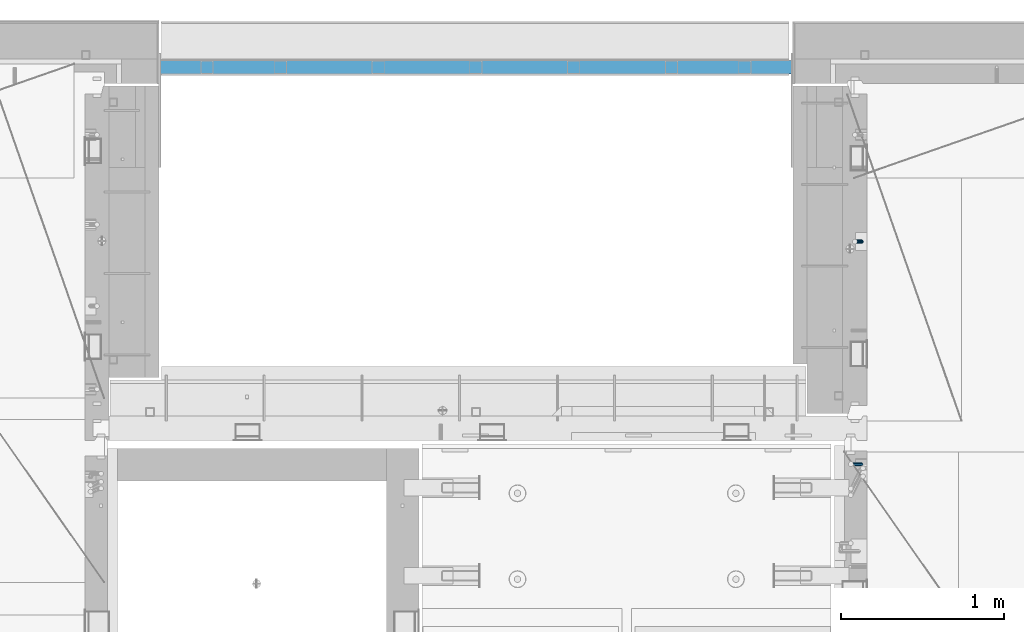
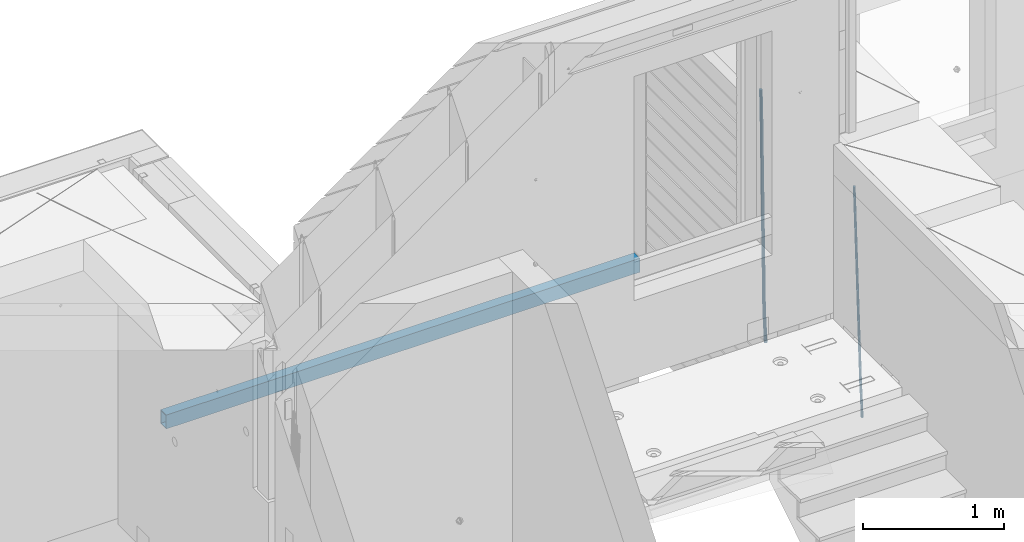
# One storey, part 125 of 350: 3 beams, 3 elements without a shape of their own.
"""IFC2X3 building model written with IfcOpenShell, lengths in millimetres."""

from ifc_helpers import new_model, si_unit, frame, origin_with_axes, place, context, subcontext, project, spatial, faceted_brep, material, type_object, element, aggregate, save


model = new_model("IFC2X3")

# Units and contexts
model_context = context("Model", 3, precision=1e-05, world=origin_with_axes())
body_context = subcontext(model_context, "Body", "Model", "MODEL_VIEW")
ifc_project = project(units=[si_unit("LENGTHUNIT", "METRE", prefix="MILLI"), si_unit("AREAUNIT", "SQUARE_METRE"), si_unit("VOLUMEUNIT", "CUBIC_METRE"), si_unit("MASSUNIT", "GRAM", prefix="KILO"), si_unit("TIMEUNIT", "SECOND"), si_unit("PLANEANGLEUNIT", "RADIAN"), si_unit("SOLIDANGLEUNIT", "STERADIAN"), si_unit("THERMODYNAMICTEMPERATUREUNIT", "DEGREE_CELSIUS"), si_unit("LUMINOUSINTENSITYUNIT", "LUMEN")], contexts=[model_context])

# Site, building, storey
site_placement = place(None, origin_with_axes())
site = spatial("IfcSite", under=ifc_project, at=site_placement, CompositionType="ELEMENT")
building_placement = place(site_placement, origin_with_axes())
building = spatial("IfcBuilding", under=site, at=building_placement, CompositionType="ELEMENT")
storey_placement = place(building_placement, origin_with_axes())
storey = spatial("IfcBuildingStorey", under=building, at=storey_placement, Name="2", CompositionType="ELEMENT", Elevation=0.0)

# Assembly, beam
assembly_1_placement = place(storey_placement, origin_with_axes())
assembly_1 = element("IfcElementAssembly", 1, at=assembly_1_placement, inside=storey, AssemblyPlace="NOTDEFINED", PredefinedType="REINFORCEMENT_UNIT")
ifc_material_1 = material()
beam_type_1 = type_object("IfcBeamType", Name="D20", PredefinedType="NOTDEFINED")
beam_1_placement = place(assembly_1_placement, frame((22375.0000022791, 20285.0000000039, 85390.0), z_axis=(-0.999642804636942, -0.000205726999925762, -0.0267249099902983), x_axis=(-0.0267249099948371, 4.30000201934385e-08, 0.999642825806181)))
beam_1 = element("IfcBeam", 2, at=beam_1_placement, type_object=beam_type_1, material=ifc_material_1, Name="JM20", ObjectType="D20", context=body_context, shape_type="Brep", body=[
    faceted_brep([(0.0, -10.0, 0.0), (-4.19531716033816e-08, -7.07106781186667, -7.07106781187031), (60.4266690400545, -7.0710677960451, -7.07106780570757), (60.4266690441291, -9.99999998418934, 6.15546014159918e-09), (0.0, 0.0, -10.0), (60.426669036824, 1.58106558956206e-08, -9.99999999384454), (4.196772351861e-08, 7.07106781186303, -7.07106781186667), (60.4266690363438, 7.07106782768096, -7.07106780570757), (0.0, 10.0, 0.0), (60.4266690388904, 10.0000000158179, 6.15182216279209e-09), (4.196772351861e-08, 7.07106781185939, 7.07106781185939), (60.4266690429649, 7.07106782768096, 7.07106781802577), (0.0, 0.0, 10.0), (60.4266690461809, 1.58179318532348e-08, 10.0000000061555), (-4.19531716033816e-08, -7.07106781187031, 7.07106781185939), (60.4266690466611, -7.07106779605238, 7.07106781802213), (61.0378400410118, -7.07106779588503, -7.07106780564936), (60.991799419251, -9.99999998403655, 6.21366780251265e-09), (61.0569027789461, 1.5985278878361e-08, -9.99999999378269), (61.0378209396877, 7.07106782784831, -7.07106780564936), (60.9917724058905, 10.0000000159635, 6.21366780251265e-09), (60.9457317841297, 7.07106782781193, 7.0710678180767), (60.9266690461809, 1.59488990902901e-08, 10.0000000062028), (60.9457508854539, -7.07106779591413, 7.0710678180767), (61.6489592143771, -7.07106614513759, -7.06310863441468), (61.5568818710308, -9.9999984576425, 0.00735959856683621), (61.6870830769039, 1.71821739058942e-06, -9.99179257185824), (61.6489210170112, 7.07106947854481, -7.06310888312146), (61.556827851804, 10.0000015422847, 0.00735924683976918), (61.4647505084577, 7.07106922979438, 7.07782747982128), (61.4266266459163, 1.36643211590126e-06, 10.0065114172685), (61.464788705809, -7.07106639389531, 7.07782772852806), (176.543135720174, -7.07075579406956, -5.56673531796696), (176.451058376813, -9.99968810657447, 1.50373291501455), (176.581259582701, 0.000312069292704109, -8.49541925541052), (176.543097522794, 7.07137982961285, -5.56673556667374), (176.451004357587, 10.00031189336, 1.50373256329476), (176.35892701424, 7.07137958085514, 8.57420079627263), (176.320803151699, 0.000311717507429421, 11.5028847337162), (176.358965211621, -7.07075604281999, 8.57420104497578), (177.098753836006, -7.07075429323595, -5.55949898843028), (176.98362511232, -9.99968666800123, 1.510669025065), (177.146421932586, 0.000313595905026887, -8.48805862247536), (177.098706077581, 7.07138133041735, -5.55949936166144), (176.983557571715, 10.0003133318824, 1.51066849724157), (176.868428848029, 7.07138095712435, 8.58083651073321), (176.820760751449, 0.000313067976094317, 11.5093961447819), (176.868476606425, -7.07075466652896, 8.58083688396073), (177.654312950661, -7.07075204110879, -5.54863964998367), (177.516135294456, -9.99968450931192, 1.52107783331303), (177.711524267797, 0.000315886711177882, -8.47701274570863), (177.654255632195, 7.07138358250813, -5.54864021007961), (177.516054233929, 10.0003154905207, 1.5210770412159), (177.377876577739, 7.0713830223176, 8.59079452451624), (177.320665260588, 0.000315094497636892, 11.5191676202448), (177.377933896176, -7.07075260129932, 8.59079508461218), (299.529725389817, -7.0702579820354, -3.16637947698109), (299.391547733612, -9.99919045023489, 3.90333800631561), (299.586936706939, 0.000809945799119305, -6.09475257270606), (299.529668071336, 7.07187764158152, -3.16638003707703), (299.391466673056, 10.000809549605, 3.90333721422212), (299.253289016866, 7.07187708140191, 10.9730546975188), (299.196077699729, 0.000809153574664379, 13.9014277932438), (299.253346335332, -7.07025854221502, 10.9730552576111), (300.053154890193, -7.07025586015152, -3.15614816594825), (299.971788958996, -9.99918809853989, 3.91467979818117), (300.086841216093, 0.000811972313385922, -6.08498109724314), (300.053121210876, 7.07187976355999, -3.15614826397359), (299.971753863239, 10.0008119014747, 3.91467990454839), (299.890387932071, 7.07187966407218, 10.9855078686815), (299.856701606172, 0.000811831610917579, 13.9143407999763), (299.890421611388, -7.07025595963933, 10.9855079667068), (300.576681224076, -7.07025548863749, -3.15433176753868), (300.552150063115, -9.99918768617863, 3.91669348816504), (300.586838206684, 0.000812327129096957, -6.08324633496159), (300.57667118829, 7.07188013509221, -3.15433178353487), (300.552135870385, 10.0008123138141, 3.91669346554409), (300.527604709423, 7.07188011626931, 10.9877187212514), (300.517447726816, 0.000812300502730068, 13.9166332886707), (300.52761474521, -7.07025550746039, 10.9877187372476), (1894.37298527778, -7.06912446613933, 2.37541694085667), (1894.34845411681, -9.99805666368775, 9.44644219656402), (1894.3831422604, 0.00194334961997811, -0.553497626566241), (1894.37297524199, 7.07301115758673, 2.37541692486411), (1894.34843992408, 10.0019433363086, 9.44644217394307), (1894.32390876314, 7.07301113876019, 16.5174674296468), (1894.31375178052, 0.00194332300088718, 19.4463819970697), (1894.32391879891, -7.06912448496587, 16.5174674456393), (1894.94254953373, -7.06912406195261, 2.37739306992808), (1894.864138918, -9.99805629773618, 9.44823138841821), (1895.01321576146, 0.00194379674576339, -0.551311557919689), (1895.03474228333, 7.0730116272025, 2.3777129556911), (1894.99451915483, 10.0019437947958, 9.44868377519742), (1894.9161085391, 7.07301155900859, 16.5195220936839), (1894.8454423114, 0.0019437003065832, 19.4482267215244), (1894.8239157895, -7.06912413014652, 16.5192022079245), (1895.51201837322, -7.07655005247943, 2.3849721376755), (1895.3797373289, -10.0047798068154, 9.45509349396525), (1895.6431837092, -0.00627111456196872, -0.542927306803904), (1895.69639846191, 7.06438349486052, 2.38651894584837), (1895.64049015092, 9.99352020044898, 9.45728101107306), (1895.50820910657, 7.06529044610943, 16.5274023673664), (1895.37704377061, -0.00498849180803518, 19.4553018118422), (1895.3238290179, -7.07564310123053, 16.5258555591899), (1917.3375872656, -7.36115994941429, 2.67544890068893), (1917.20530622125, -10.2893897037538, 9.74557025698232), (1917.46875260158, -0.29088101150046, -0.252450543786836), (1917.52196735426, 6.77977359792203, 2.67699570887271), (1917.46605904329, 9.70891030351049, 9.74775777409013), (1917.33377799895, 6.78068054917094, 16.8178791303835), (1917.20261266298, -0.289598388742888, 19.7457785748593), (1917.1493979103, -7.36025299817265, 16.816332322207), (1917.97302879854, -7.36944623740055, 2.68390599981285), (1917.86539582294, -10.2979974076115, 9.75435539755927), (1918.04706999661, -0.298422389005282, -0.244753710507212), (1918.04414708749, 6.77296426705288, 2.68394540532245), (1917.9659722717, 9.70239133243012, 9.75441112535555), (1917.85833929609, 6.77384016221913, 16.824860523102), (1917.78429809801, -0.297183686179778, 19.753520233422), (1917.78722100714, -7.36857034223431, 16.8248211175924), (1918.60852415283, -7.36757026622581, 2.69216814523315), (1918.52554118163, -10.29602885028, 9.76294518245413), (1918.62543662851, -0.296724680512853, -0.237251666560041), (1918.56637150982, 6.77450246020453, 2.69070014292447), (1918.46592834221, 9.70388219950109, 9.76086911367383), (1918.38294537101, 6.7754236154542, 16.8316461508839), (1918.36603289531, -0.295421970262396, 19.7610659626844), (1918.42509801401, -7.36664911097978, 16.8331141531962), (2018.62930980593, -7.06930811566781, 3.98954616814444), (2018.54632683474, -9.99776669972198, 11.0603232053618), (2018.64622228162, 0.00153747004878824, 1.06012635634761), (2018.58715716293, 7.07276461076617, 3.98807816583212), (2018.4867139953, 10.0021443500664, 11.0582471365815), (2018.40373102411, 7.0736857660122, 18.1290241737915), (2018.38681854842, 0.00284018029924482, 21.0584439855957), (2018.44588366711, -7.06838696041814, 18.1304921761075)], [[[0, 1, 2, 3]], [[1, 4, 5, 2]], [[4, 6, 7, 5]], [[6, 8, 9, 7]], [[8, 10, 11, 9]], [[10, 12, 13, 11]], [[12, 14, 15, 13]], [[14, 0, 3, 15]], [[14, 12, 10, 8, 6, 4, 1, 0]], [[3, 2, 16, 17]], [[2, 5, 18, 16]], [[5, 7, 19, 18]], [[7, 9, 20, 19]], [[9, 11, 21, 20]], [[11, 13, 22, 21]], [[13, 15, 23, 22]], [[15, 3, 17, 23]], [[17, 16, 24, 25]], [[16, 18, 26, 24]], [[18, 19, 27, 26]], [[19, 20, 28, 27]], [[20, 21, 29, 28]], [[21, 22, 30, 29]], [[22, 23, 31, 30]], [[23, 17, 25, 31]], [[25, 24, 32, 33]], [[24, 26, 34, 32]], [[26, 27, 35, 34]], [[27, 28, 36, 35]], [[28, 29, 37, 36]], [[29, 30, 38, 37]], [[30, 31, 39, 38]], [[31, 25, 33, 39]], [[33, 32, 40, 41]], [[32, 34, 42, 40]], [[34, 35, 43, 42]], [[35, 36, 44, 43]], [[36, 37, 45, 44]], [[37, 38, 46, 45]], [[38, 39, 47, 46]], [[39, 33, 41, 47]], [[41, 40, 48, 49]], [[40, 42, 50, 48]], [[42, 43, 51, 50]], [[43, 44, 52, 51]], [[44, 45, 53, 52]], [[45, 46, 54, 53]], [[46, 47, 55, 54]], [[47, 41, 49, 55]], [[49, 48, 56, 57]], [[48, 50, 58, 56]], [[50, 51, 59, 58]], [[51, 52, 60, 59]], [[52, 53, 61, 60]], [[53, 54, 62, 61]], [[54, 55, 63, 62]], [[55, 49, 57, 63]], [[57, 56, 64, 65]], [[56, 58, 66, 64]], [[58, 59, 67, 66]], [[59, 60, 68, 67]], [[60, 61, 69, 68]], [[61, 62, 70, 69]], [[62, 63, 71, 70]], [[63, 57, 65, 71]], [[65, 64, 72, 73]], [[64, 66, 74, 72]], [[66, 67, 75, 74]], [[67, 68, 76, 75]], [[68, 69, 77, 76]], [[69, 70, 78, 77]], [[70, 71, 79, 78]], [[71, 65, 73, 79]], [[73, 72, 80, 81]], [[72, 74, 82, 80]], [[74, 75, 83, 82]], [[75, 76, 84, 83]], [[76, 77, 85, 84]], [[77, 78, 86, 85]], [[78, 79, 87, 86]], [[79, 73, 81, 87]], [[81, 80, 88, 89]], [[80, 82, 90, 88]], [[82, 83, 91, 90]], [[83, 84, 92, 91]], [[84, 85, 93, 92]], [[85, 86, 94, 93]], [[86, 87, 95, 94]], [[87, 81, 89, 95]], [[89, 88, 96, 97]], [[88, 90, 98, 96]], [[90, 91, 99, 98]], [[91, 92, 100, 99]], [[92, 93, 101, 100]], [[93, 94, 102, 101]], [[94, 95, 103, 102]], [[95, 89, 97, 103]], [[97, 96, 104, 105]], [[96, 98, 106, 104]], [[98, 99, 107, 106]], [[99, 100, 108, 107]], [[100, 101, 109, 108]], [[101, 102, 110, 109]], [[102, 103, 111, 110]], [[103, 97, 105, 111]], [[105, 104, 112, 113]], [[104, 106, 114, 112]], [[106, 107, 115, 114]], [[107, 108, 116, 115]], [[108, 109, 117, 116]], [[109, 110, 118, 117]], [[110, 111, 119, 118]], [[111, 105, 113, 119]], [[113, 112, 120, 121]], [[112, 114, 122, 120]], [[114, 115, 123, 122]], [[115, 116, 124, 123]], [[116, 117, 125, 124]], [[117, 118, 126, 125]], [[118, 119, 127, 126]], [[119, 113, 121, 127]], [[121, 120, 128, 129]], [[120, 122, 130, 128]], [[122, 123, 131, 130]], [[123, 124, 132, 131]], [[124, 125, 133, 132]], [[125, 126, 134, 133]], [[126, 127, 135, 134]], [[127, 121, 129, 135]], [[130, 131, 132, 133, 134, 135, 129, 128]]]),
])
aggregate(assembly_1, [beam_1])

assembly_2_placement = place(storey_placement, origin_with_axes())
assembly_2 = element("IfcElementAssembly", 3, at=assembly_2_placement, inside=storey, Name="(PD)", AssemblyPlace="NOTDEFINED", PredefinedType="REINFORCEMENT_UNIT")
beam_type_2 = type_object("IfcBeamType", Name="D25", PredefinedType="NOTDEFINED")
beam_2_placement = place(assembly_2_placement, frame((22375.0000022791, 21650.0000022831, 85210.0), z_axis=(-0.999642804636942, -0.000205726999925762, -0.0267249099902983), x_axis=(-0.0267249099948371, 4.30000201934385e-08, 0.999642825806181)))
beam_2 = element("IfcBeam", 4, at=beam_2_placement, type_object=beam_type_2, material=ifc_material_1, Name="JM25", ObjectType="D25", context=body_context, shape_type="Brep", body=[
    faceted_brep([(-7.41420080885291e-08, -12.5, -3.63797880709171e-12), (-6.42030499875546e-08, -10.8253175473074, -6.25000000000364), (60.3648172924295, -10.8253175319842, -6.24999999382999), (60.3648172957764, -12.4999999846732, 6.17001205682755e-09), (-3.70782800018787e-08, -6.25000000000364, -10.8253175473074), (60.3648172891262, -6.2499999846732, -10.8253175411337), (-1.45519152283669e-11, -3.63797880709171e-12, -12.5), (60.3648172867543, 1.53268047142774e-08, -12.49999999383), (3.70637280866504e-08, 6.25, -10.8253175473074), (60.3648172859539, 6.25000001531953, -10.8253175411337), (6.42030499875546e-08, 10.8253175473001, -6.25000000000364), (60.3648172869289, 10.8253175626269, -6.24999999382635), (7.41420080885291e-08, 12.4999999999927, 0.0), (60.3648172894173, 12.5000000153268, 6.17001205682755e-09), (6.42176019027829e-08, 10.8253175473001, 6.24999999999636), (60.3648172927933, 10.8253175626305, 6.25000000617365), (3.70928319171071e-08, 6.24999999999636, 10.8253175473037), (60.3648172960675, 6.25000001532317, 10.8253175534737), (1.45519152283669e-11, -3.63797880709171e-12, 12.4999999999964), (60.364817298454, 1.53231667354703e-08, 12.5000000061737), (-3.7049176171422e-08, -6.25000000000364, 10.8253175473001), (60.3648172992398, -6.24999998467683, 10.825317553481), (-6.41884980723262e-08, -10.8253175473074, 6.25), (60.3648172982794, -10.8253175319842, 6.25000000617001), (61.0552930214471, -10.8253175318059, -6.24999999376087), (60.991802792938, -12.4999999843931, 6.22458173893392e-09), (61.1017571225239, -6.24999998448766, -10.8253175410646), (61.1187545266876, 1.55159796122462e-08, -12.4999999937536), (61.1017307932489, 6.2500000155087, -10.8253175410573), (61.0552474178112, 10.8253175628051, -6.24999999376087), (60.9917690322181, 12.5000000156033, 6.22458173893392e-09), (60.9282788036944, 10.825317562776, 6.25000000622458), (60.8818147026177, 6.25000001545413, 10.8253175535319), (60.864817298454, 1.54504959937185e-08, 12.5000000062246), (60.8818410318927, -6.24999998454223, 10.8253175535283), (60.9283244073304, -10.8253175318387, 6.25000000622822), (61.7456262860651, -10.8253146235293, -6.23597444070037), (61.6186778213741, -12.4999973436206, 0.0127360815422435), (61.8385449046473, -6.24999688050229, -10.8103481680628), (61.8725362083496, 3.19109676638618e-06, -12.4846853544113), (61.838492254712, 6.25000311938493, -10.8103487028166), (61.7455350936798, 10.8253204708963, -6.23597536692614), (61.6185725214746, 12.5000026561611, 0.0127350120237679), (61.4916240567691, 10.8253199360734, 6.26144553427366), (61.3987054381723, 6.25000219304275, 10.8358192616288), (61.3647141345136, 2.12145096156746e-06, 12.5101564479846), (61.3987580881076, -6.2499978068372, 10.8358197963862), (61.4917152491544, -10.8253151583522, 6.26144646049579), (279.392687193496, -10.8243977058919, -1.81402267131125), (279.265738728776, -12.4990804259869, 4.43468785092773), (279.485605812079, -6.24907996286856, -6.38839639867365), (279.519597115752, 0.000920108730497304, -8.06273358503313), (279.485553162143, 6.25092003701866, -6.38839693343471), (279.392596001097, 10.8262373885264, -1.81402359754429), (279.265633428906, 12.5009195737948, 4.43468678140925), (279.1386849642, 10.8262368536998, 10.6833973036555), (279.045766345604, 6.25091911067648, 15.2577710310143), (279.011775041945, 0.000919039084692486, 16.9321082173701), (279.045818995539, -6.24908088920711, 15.257771565779), (279.138776156586, -10.8243982407148, 10.6833982298813), (279.999211786053, -10.8243951506884, -1.80169986537658), (279.978923396819, -12.4990774214348, 4.44917767767402), (280.014061639828, -6.24907773655286, -6.37765972172565), (280.019493951797, 0.000922214727324899, -8.05257714326581), (280.01405313838, 6.25092226351626, -6.37765935951393), (279.99919706113, 10.8262399440573, -1.80169923800713), (279.978906393953, 12.500922578718, 4.44917840209746), (279.958618004719, 10.826240307968, 10.7000559451481), (279.943768150944, 6.2509228938361, 15.2760158014935), (279.93833583899, 0.00092294255955494, 16.9509332230373), (279.943776652392, -6.24907710623302, 15.2760154392854), (279.958632729657, -10.8243947867741, 10.7000553177786), (280.605803594066, -10.8243968809475, -1.81008505401405), (280.692187100445, -12.4990794559708, 4.43931791592695), (280.542576031381, -6.24907924410218, -6.38496561147258), (280.51944618675, 0.000920788650546456, -8.05948820561025), (280.542611683326, 6.25092075584325, -6.38496585961548), (280.605865345075, 10.8262382135763, -1.81008548380851), (280.69225840435, 12.5009205439346, 4.43931741964479), (280.778641910743, 10.826237968904, 10.6887203895858), (280.841869473428, 6.25092033206965, 15.2636009470443), (280.864999318059, 0.00092029931693105, 16.938123541182), (280.841833821454, -6.24907966787578, 15.2636011951872), (280.778580159735, -10.8243971256161, 10.6887208193803), (2073.42296507982, -10.8295107683043, -26.5929949090023), (2073.5093485862, -12.5041933433276, -20.3435919390613), (2073.35973751714, -6.25419313146267, -31.1678754664645), (2073.33660767249, -0.00419309870994766, -32.8423980606021), (2073.3597731691, 6.2458068684864, -31.1678757146037), (2073.42302683082, 10.8211243262158, -26.5929953387968), (2073.50941989011, 12.4958066565741, -20.3435924353507), (2073.5958033965, 10.8211240815508, -14.0941894654061), (2073.65903095918, 6.24580644470916, -9.51930890794756), (2073.68216080382, -0.00419358803992509, -7.84478631380989), (2073.65899530721, -6.25419355524355, -9.51930865980466), (2073.59574164549, -10.8295110129729, -14.094189035608), (2074.12470923731, -10.8295127699821, -26.6026954309382), (2074.11539927781, -12.5041950720442, -20.3519696476105), (2074.15336664949, -6.25419539523864, -31.1788461553151), (2074.19369278394, -0.00419554348263773, -32.8542459297059), (2074.2348822855, 6.24580437229815, -31.1799727375546), (2074.26589846046, 10.8211219219847, -26.6046467286178), (2074.27843054984, 12.4958044630221, -20.3542228120896), (2074.26912059034, 10.8211221609563, -14.1034970287619), (2074.24046317814, 6.24580478621283, -9.52734630438863), (2074.20013704371, -0.00419506553225801, -7.8519465299978), (2074.15894754215, -6.25419498132032, -9.52621972214547), (2074.12793136717, -10.8295125310069, -14.1015457310859), (2074.82639864438, -10.8386629434463, -26.5933566383756), (2074.72140268509, -12.5120974804886, -20.3439043411418), (2074.94693386253, -6.26454367409315, -31.1682845599535), (2075.05071102524, -0.0153712367318803, -32.8428398638644), (2075.10992312549, 6.23439366067396, -31.1683268087399), (2075.10870432889, 10.8101315609856, -26.5934298154134), (2075.04738121096, 12.4857771890383, -20.3439888387111), (2074.94238525168, 10.812342651996, -14.0945365414773), (2074.82185003351, 6.2382233826429, -9.51960861989573), (2074.7180728708, -0.0109490547110909, -7.84505331599212), (2074.65886077055, -6.26071395212057, -9.51956637111289), (2074.66007956718, -10.8364518524359, -14.0944633644431), (2096.52525293056, -11.1216204438242, -26.3045663317826), (2096.42025697125, -12.7950549808702, -20.0551140345524), (2096.64578814874, -6.54750117447475, -30.8794942533677), (2096.74956531142, -0.298328737113479, -32.5540495572714), (2096.80877741167, 5.95143616029236, -30.8795365021469), (2096.80755861507, 10.5271740606076, -26.3046395088204), (2096.74623549715, 12.2028196886604, -20.0551985321181), (2096.64123953786, 10.5293851516144, -13.8057462348843), (2096.52070431967, 5.95526588226494, -9.23081831330273), (2096.416927157, -0.29390655509269, -7.55626300939548), (2096.35771505673, -6.54367145250217, -9.23077606452716), (2096.35893385335, -11.1194093528175, -13.8056730578464), (2097.21092783989, -11.1305617849575, -26.2954406763638), (2097.12039112388, -12.8041848734974, -20.0457959408886), (2097.29405363984, -6.55595468913816, -30.8708664803271), (2097.34749503279, -0.306125863040506, -32.5460917035853), (2097.35693244069, 5.94428810654063, -30.8722411004273), (2097.31983711764, 10.5204938440984, -26.297821588214), (2097.24614872556, 12.1963007178601, -20.0485451810855), (2097.15561200958, 10.5226776293239, -13.7989004456176), (2097.0724862096, 5.94807053350087, -9.22347464165432), (2097.01904481664, -0.301758292589511, -7.54824941839615), (2097.00960740878, -6.55217226217792, -9.22210002155407), (2097.04670273181, -11.128377999732, -13.7965195337638), (2097.89666070435, -11.1285336977271, -26.2865169430515), (2097.8205843524, -12.8020968893979, -20.0366801492601), (2097.94237410219, -6.55405044857616, -30.8624403040376), (2097.94547567789, -0.30437623434409, -32.5383352630161), (2097.90513436675, 5.94589378631281, -30.8651471191333), (2097.83215959051, 10.5220048088704, -26.2912052843276), (2097.74610488152, 12.1977915803764, -20.0420937794624), (2097.67002852958, 10.5242283887019, -13.792256985671), (2097.62431513173, 5.94974513955094, -9.21633362468492), (2097.62121355605, -0.299929074681131, -7.54043866570282), (2097.66155486718, -6.55019909533439, -9.21362680958555), (2097.73452964344, -11.1263101178956, -13.7875686443949), (2197.89742227788, -10.8303313310134, -24.989402432675), (2197.82134592593, -12.5038945226843, -18.7395656388908), (2197.9431356757, -6.25584808185886, -29.565325793661), (2197.9462372514, -0.00617386763042305, -31.2412207526431), (2197.90589594025, 6.24409615302648, -29.5680326087568), (2197.83292116401, 10.8202071755841, -24.9940907739547), (2197.74686645503, 12.4959939470864, -18.7449792690859), (2197.67079010308, 10.8224307554156, -12.4951424753017), (2197.62507670524, 6.24794750626461, -7.919219114312), (2197.62197512954, -0.00172670796746388, -6.2433241553299), (2197.66231644071, -6.25199672862436, -7.91651229921263), (2197.73529121693, -10.828107751182, -12.4904541340184)], [[[0, 1, 2, 3]], [[1, 4, 5, 2]], [[4, 6, 7, 5]], [[6, 8, 9, 7]], [[8, 10, 11, 9]], [[10, 12, 13, 11]], [[12, 14, 15, 13]], [[14, 16, 17, 15]], [[16, 18, 19, 17]], [[18, 20, 21, 19]], [[20, 22, 23, 21]], [[22, 0, 3, 23]], [[22, 20, 18, 16, 14, 12, 10, 8, 6, 4, 1, 0]], [[3, 2, 24, 25]], [[2, 5, 26, 24]], [[5, 7, 27, 26]], [[7, 9, 28, 27]], [[9, 11, 29, 28]], [[11, 13, 30, 29]], [[13, 15, 31, 30]], [[15, 17, 32, 31]], [[17, 19, 33, 32]], [[19, 21, 34, 33]], [[21, 23, 35, 34]], [[23, 3, 25, 35]], [[25, 24, 36, 37]], [[24, 26, 38, 36]], [[26, 27, 39, 38]], [[27, 28, 40, 39]], [[28, 29, 41, 40]], [[29, 30, 42, 41]], [[30, 31, 43, 42]], [[31, 32, 44, 43]], [[32, 33, 45, 44]], [[33, 34, 46, 45]], [[34, 35, 47, 46]], [[35, 25, 37, 47]], [[37, 36, 48, 49]], [[36, 38, 50, 48]], [[38, 39, 51, 50]], [[39, 40, 52, 51]], [[40, 41, 53, 52]], [[41, 42, 54, 53]], [[42, 43, 55, 54]], [[43, 44, 56, 55]], [[44, 45, 57, 56]], [[45, 46, 58, 57]], [[46, 47, 59, 58]], [[47, 37, 49, 59]], [[49, 48, 60, 61]], [[48, 50, 62, 60]], [[50, 51, 63, 62]], [[51, 52, 64, 63]], [[52, 53, 65, 64]], [[53, 54, 66, 65]], [[54, 55, 67, 66]], [[55, 56, 68, 67]], [[56, 57, 69, 68]], [[57, 58, 70, 69]], [[58, 59, 71, 70]], [[59, 49, 61, 71]], [[61, 60, 72, 73]], [[60, 62, 74, 72]], [[62, 63, 75, 74]], [[63, 64, 76, 75]], [[64, 65, 77, 76]], [[65, 66, 78, 77]], [[66, 67, 79, 78]], [[67, 68, 80, 79]], [[68, 69, 81, 80]], [[69, 70, 82, 81]], [[70, 71, 83, 82]], [[71, 61, 73, 83]], [[73, 72, 84, 85]], [[72, 74, 86, 84]], [[74, 75, 87, 86]], [[75, 76, 88, 87]], [[76, 77, 89, 88]], [[77, 78, 90, 89]], [[78, 79, 91, 90]], [[79, 80, 92, 91]], [[80, 81, 93, 92]], [[81, 82, 94, 93]], [[82, 83, 95, 94]], [[83, 73, 85, 95]], [[85, 84, 96, 97]], [[84, 86, 98, 96]], [[86, 87, 99, 98]], [[87, 88, 100, 99]], [[88, 89, 101, 100]], [[89, 90, 102, 101]], [[90, 91, 103, 102]], [[91, 92, 104, 103]], [[92, 93, 105, 104]], [[93, 94, 106, 105]], [[94, 95, 107, 106]], [[95, 85, 97, 107]], [[97, 96, 108, 109]], [[96, 98, 110, 108]], [[98, 99, 111, 110]], [[99, 100, 112, 111]], [[100, 101, 113, 112]], [[101, 102, 114, 113]], [[102, 103, 115, 114]], [[103, 104, 116, 115]], [[104, 105, 117, 116]], [[105, 106, 118, 117]], [[106, 107, 119, 118]], [[107, 97, 109, 119]], [[109, 108, 120, 121]], [[108, 110, 122, 120]], [[110, 111, 123, 122]], [[111, 112, 124, 123]], [[112, 113, 125, 124]], [[113, 114, 126, 125]], [[114, 115, 127, 126]], [[115, 116, 128, 127]], [[116, 117, 129, 128]], [[117, 118, 130, 129]], [[118, 119, 131, 130]], [[119, 109, 121, 131]], [[121, 120, 132, 133]], [[120, 122, 134, 132]], [[122, 123, 135, 134]], [[123, 124, 136, 135]], [[124, 125, 137, 136]], [[125, 126, 138, 137]], [[126, 127, 139, 138]], [[127, 128, 140, 139]], [[128, 129, 141, 140]], [[129, 130, 142, 141]], [[130, 131, 143, 142]], [[131, 121, 133, 143]], [[133, 132, 144, 145]], [[132, 134, 146, 144]], [[134, 135, 147, 146]], [[135, 136, 148, 147]], [[136, 137, 149, 148]], [[137, 138, 150, 149]], [[138, 139, 151, 150]], [[139, 140, 152, 151]], [[140, 141, 153, 152]], [[141, 142, 154, 153]], [[142, 143, 155, 154]], [[143, 133, 145, 155]], [[145, 144, 156, 157]], [[144, 146, 158, 156]], [[146, 147, 159, 158]], [[147, 148, 160, 159]], [[148, 149, 161, 160]], [[149, 150, 162, 161]], [[150, 151, 163, 162]], [[151, 152, 164, 163]], [[152, 153, 165, 164]], [[153, 154, 166, 165]], [[154, 155, 167, 166]], [[155, 145, 157, 167]], [[158, 159, 160, 161, 162, 163, 164, 165, 166, 167, 157, 156]]]),
])
aggregate(assembly_2, [beam_2])

assembly_3_placement = place(storey_placement, origin_with_axes())
assembly_3 = element("IfcElementAssembly", 5, at=assembly_3_placement, inside=storey, Name="Steel Assembly", AssemblyPlace="NOTDEFINED", PredefinedType="RIGID_FRAME")
ifc_material_2 = material()
beam_type_3 = type_object("IfcBeamType", Name="120X80X5", PredefinedType="NOTDEFINED")
beam_3_placement = place(assembly_3_placement, frame((18074.9964796215, 22720.0048216061, 85400.0), z_axis=(0.0, 0.0, 1.0), x_axis=(1.0, 0.0, 0.0)))
beam_3 = element("IfcBeam", 6, at=beam_3_placement, type_object=beam_type_3, material=ifc_material_2, Name="BEAM", ObjectType="120X80X5", context=body_context, shape_type="Brep", body=[
    faceted_brep([(0.0, 35.0, -55.0), (0.0, -35.0, -55.0), (3870.00292590763, -35.0, -55.0), (3870.00292590763, 35.0, -55.0), (0.0, -35.0, 55.0), (3870.00292590763, -35.0, 55.0), (0.0, 35.0, 55.0), (3870.00292590763, 35.0, 55.0), (0.0, 40.0, -60.0), (0.0, 40.0, 60.0), (3870.00292590763, 40.0, 60.0), (3870.00292590763, 40.0, -60.0), (0.0, -40.0, 60.0), (3870.00292590763, -40.0, 60.0), (0.0, -40.0, -60.0), (3870.00292590763, -40.0, -60.0)], [[[0, 1, 2, 3]], [[1, 4, 5, 2]], [[4, 6, 7, 5]], [[6, 0, 3, 7]], [[8, 9, 10, 11]], [[9, 12, 13, 10]], [[12, 14, 15, 13]], [[14, 8, 11, 15]], [[13, 15, 11, 10], [5, 7, 3, 2]], [[14, 12, 9, 8], [6, 4, 1, 0]]]),
])
aggregate(assembly_3, [beam_3])

save(model, "model.ifc")
